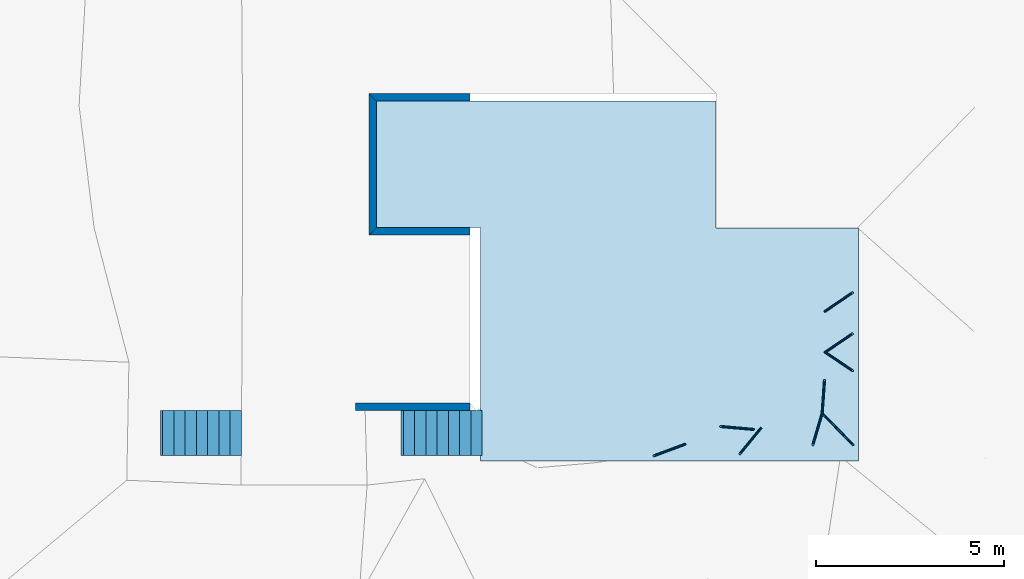
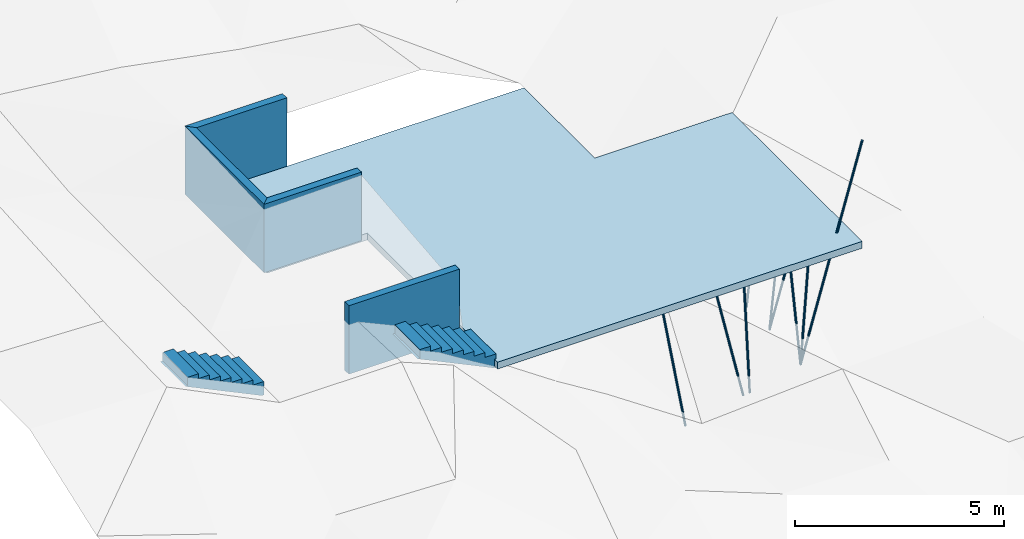
# Not in any storey, part 1 of 2: 9 columns, 4 walls, 2 stair flights, 1 slab.
"""IFC4 model written with IfcOpenShell, lengths in metres."""

from ifc_helpers import new_model, entity, si_unit, converted_unit, frame, origin_with_axes, origin_2d_with_axis, place, context, subcontext, project, line, indexed_curve, circle, outline, extrude, clip, halfspace, polygons, source, transform, mapped, material, layer, layer_set, layer_usage, material_profile, profile_set, profile_usage, type_object, type_shapes, element, save


model = new_model("IFC4")

# Units and contexts
model_context = context("Model", 3, precision=1e-05, world=origin_with_axes())
plan_context = context("Plan", 2, precision=1e-05, world=origin_2d_with_axis())
body_context = subcontext(model_context, "Body", "Model", "MODEL_VIEW")
ifc_project = project(units=[si_unit("LENGTHUNIT", "METRE"), converted_unit("PLANEANGLEUNIT", "degree", entity("IfcReal", 0.0174532925199433), si_unit("PLANEANGLEUNIT", "RADIAN"), dimensions=[0, 0, 0, 0, 0, 0, 0]), si_unit("AREAUNIT", "SQUARE_METRE"), si_unit("VOLUMEUNIT", "CUBIC_METRE")], contexts=[model_context, plan_context])

# Columns
ifc_material = material()
ifc_material_profile = material_profile(ifc_material, circle(Radius=0.0299999993294477))
ifc_profile_set = profile_set([ifc_material_profile])
ifc_profile_usage_1 = profile_usage(ifc_profile_set, cardinal=5)
column_type = type_object("IfcColumnType", Name="Column", PredefinedType="COLUMN", material=ifc_profile_set)
column_1_placement = place(None, frame((4.1066460609436, -0.0712302401661873, -4.02319383621216), z_axis=(0.152964162685084, -0.156363311331579, 0.975783008564648), x_axis=(0.714833945267838, 0.69929423756586, -1.07349813621721e-08)))
element("IfcColumn", 1, at=column_1_placement, type_object=column_type, material=ifc_profile_usage_1, Name="Column", context=body_context, shape_type="SweptSolid", body=[
    extrude(circle(Radius=0.0299999993294477), origin_with_axes(), (0.0, 0.0, 1.0), 7.0000000510897),
])
ifc_profile_usage_2 = profile_usage(ifc_profile_set, cardinal=5)
column_2_placement = place(None, frame((4.1066460609436, -0.0712302401661873, -4.02319383621216), z_axis=(-0.0616105100448784, -0.209884871619059, 0.975783011595027), x_axis=(0.959514275210557, -0.281660000119222, -1.07349815166378e-08)))
element("IfcColumn", 2, at=column_2_placement, type_object=column_type, material=ifc_profile_usage_2, Name="Column", context=body_context, shape_type="SweptSolid", body=[
    extrude(circle(Radius=0.0299999993294477), origin_with_axes(), (0.0, 0.0, 1.0), 3.99999987334013),
])
ifc_profile_usage_3 = profile_usage(ifc_profile_set, cardinal=5)
column_3_placement = place(None, frame((4.1066460609436, -0.0712302401661873, -4.02319383621216), z_axis=(0.0154974454944706, 0.218191062591137, 0.975783013476099), x_axis=(-0.997487086280156, 0.0708485194222474, -1.07349814937929e-08)))
element("IfcColumn", 3, at=column_3_placement, type_object=column_type, material=ifc_profile_usage_3, Name="Column", context=body_context, shape_type="SweptSolid", body=[
    extrude(circle(Radius=0.0299999993294477), origin_with_axes(), (0.0, 0.0, 1.0), 3.99999987334013),
])
ifc_profile_usage_4 = profile_usage(ifc_profile_set, cardinal=5)
column_4_placement = place(None, frame((2.47132182121277, -0.47253680229187, -4.02319383621216), z_axis=(-0.138579714688634, -0.169242937508952, 0.975783014189199), x_axis=(0.77371471493996, -0.63353416631258, -1.07349806949325e-08)))
element("IfcColumn", 4, at=column_4_placement, type_object=column_type, material=ifc_profile_usage_4, Name="Column", context=body_context, shape_type="SweptSolid", body=[
    extrude(circle(Radius=0.0299999993294477), origin_with_axes(), (0.0, 0.0, 1.0), 3.99999987334013),
])
ifc_profile_usage_5 = profile_usage(ifc_profile_set, cardinal=5)
column_5_placement = place(None, frame((4.18690729141235, 1.55406141281128, -4.02319383621216), z_axis=(0.18098047837806, 0.12285590485522, 0.975783015371888), x_axis=(-0.561650777722652, 0.827374403691303, -1.07349816273892e-08)))
element("IfcColumn", 5, at=column_5_placement, type_object=column_type, material=ifc_profile_usage_5, Name="Column", context=body_context, shape_type="SweptSolid", body=[
    extrude(circle(Radius=0.0299999993294477), origin_with_axes(), (0.0, 0.0, 1.0), 3.99999987334013),
])
ifc_profile_usage_6 = profile_usage(ifc_profile_set, cardinal=5)
column_6_placement = place(None, frame((4.18690729141235, 1.55406141281128, -4.02319383621216), z_axis=(0.181584452652041, -0.121961425642809, 0.975783017484027), x_axis=(0.557561659392835, 0.830135528678967, -1.07349816145693e-08)))
element("IfcColumn", 6, at=column_6_placement, type_object=column_type, material=ifc_profile_usage_6, Name="Column", context=body_context, shape_type="SweptSolid", body=[
    extrude(circle(Radius=0.0299999993294477), origin_with_axes(), (0.0, 0.0, 1.0), 3.99999987334013),
])
ifc_profile_usage_7 = profile_usage(ifc_profile_set, cardinal=5)
column_7_placement = place(None, frame((2.27528548240662, -0.501705825328827, -4.02319383621216), z_axis=(-0.217891982431581, 0.0192505946267549, 0.975783018195414), x_axis=(-0.0880065055008526, -0.996119899906396, -1.07349802343716e-08)))
element("IfcColumn", 7, at=column_7_placement, type_object=column_type, material=ifc_profile_usage_7, Name="Column", context=body_context, shape_type="SweptSolid", body=[
    extrude(circle(Radius=0.0299999993294477), origin_with_axes(), (0.0, 0.0, 1.0), 3.99999987334013),
])
ifc_profile_usage_8 = profile_usage(ifc_profile_set, cardinal=5)
column_8_placement = place(None, frame((4.18690729141235, 2.64762187004089, -4.02319383621216), z_axis=(0.18098047837806, 0.12285590485522, 0.975783015371888), x_axis=(-0.561650777722652, 0.827374403691303, -1.07349816273892e-08)))
element("IfcColumn", 8, at=column_8_placement, type_object=column_type, material=ifc_profile_usage_8, Name="Column", context=body_context, shape_type="SweptSolid", body=[
    extrude(circle(Radius=0.0299999993294477), origin_with_axes(), (0.0, 0.0, 1.0), 3.99999987334013),
])
ifc_profile_usage_9 = profile_usage(ifc_profile_set, cardinal=5)
column_9_placement = place(None, frame((0.448067605495453, -0.898925006389618, -4.02319383621216), z_axis=(-0.20505814848983, -0.0761489070684512, 0.975783018754786), x_axis=(0.348124034486287, -0.937448482111412, -1.07349811581041e-08)))
element("IfcColumn", 9, at=column_9_placement, type_object=column_type, material=ifc_profile_usage_9, Name="Column", context=body_context, shape_type="SweptSolid", body=[
    extrude(circle(Radius=0.0299999993294477), origin_with_axes(), (0.0, 0.0, 1.0), 3.99999987334013),
])

# Slab
ifc_layer_1 = layer(ifc_material, 0.200000002980232)
ifc_layer_set_1 = layer_set([ifc_layer_1])
ifc_layer_usage_1 = layer_usage(ifc_layer_set_1, "AXIS3", "POSITIVE", 0.0)
slab_type = type_object("IfcSlabType", Name="Concrete Slab", PredefinedType="FLOOR", material=ifc_layer_set_1)
slab_placement = place(None, frame((1.27500009536743, 0.0, -0.200000002980232), z_axis=(0.0, 0.0, 1.0), x_axis=(1.0, 0.0, 0.0)))
element("IfcSlab", 10, at=slab_placement, type_object=slab_type, material=ifc_layer_usage_1, Name="Slab", context=body_context, shape_type="SweptSolid", body=[
    extrude(outline(indexed_curve([(2.62260437011719e-06, 8.25), (-9.04509925842285, 8.25), (-9.04509925842285, 4.87499904632568), (-6.27499961853027, 4.87499904632568), (-6.27499437332153, -1.34256982803345), (3.79840803146362, -1.34256982803345), (3.79840803146362, 4.86853408813477), (1.9073486328125e-06, 4.86853408813477)], segments=[line(5, 6), line(6, 7), line(7, 8), line(8, 1), line(1, 2), line(2, 3), line(3, 4), line(4, 5)], self_intersect=False)), None, (0.0, 0.0, 1.0), 0.200000002980232),
])

# Walls
ifc_layer_2 = layer(ifc_material, 0.200000002980232)
ifc_layer_set_2 = layer_set([ifc_layer_2])
ifc_layer_usage_2 = layer_usage(ifc_layer_set_2, "AXIS2", "POSITIVE", 0.0)
wall_type = type_object("IfcWallType", Name="Retaining Wall", PredefinedType="SOLIDWALL", material=ifc_layer_set_2)
wall_1_placement = place(None, frame((-7.97009992599487, 4.67499923706055, 0.0), z_axis=(0.0, 0.0, 1.0), x_axis=(1.0, 0.0, 0.0)))
element("IfcWall", 11, at=wall_1_placement, type_object=wall_type, material=ifc_layer_usage_2, Name="Wall", context=body_context, shape_type="Clipping", body=[
    clip(extrude(outline(indexed_curve([(0.0, 0.0), (0.0, 0.200000002980232), (2.69510223010764, 0.200000002980232), (2.69510223010764, 0.0), (0.0, 0.0)], self_intersect=False)), origin_with_axes(), (0.0, 0.0, 1.0), 2.0), halfspace(frame((4.76837158203125e-07, 0.0, 0.0), z_axis=(-0.707107603549957, 0.707105934619904, 0.0), x_axis=(0.707105946721014, 0.707107615651096, 0.0)), False)),
])
ifc_layer_usage_3 = layer_usage(ifc_layer_set_2, "AXIS2", "POSITIVE", 0.0)
wall_2_placement = place(None, frame((-7.97010040283203, 8.44999885559082, 0.0), z_axis=(0.0, 0.0, 1.0), x_axis=(3.13916473260163e-07, -0.999999999999951, 0.0)))
element("IfcWall", 12, at=wall_2_placement, type_object=wall_type, material=ifc_layer_usage_3, Name="Wall", context=body_context, shape_type="Clipping", body=[
    clip(clip(extrude(outline(indexed_curve([(0.0, 0.0), (0.0, 0.200000002980232), (3.77499957558345, 0.200000002980232), (3.77499957558345, 0.0), (0.0, 0.0)], self_intersect=False)), origin_with_axes(), (0.0, 0.0, 1.0), 2.0), halfspace(frame((3.59077148459619e-07, -2.08429128178977e-07, 0.0), z_axis=(-0.707106471061707, 0.707106947898865, 0.0), x_axis=(0.707107019605111, 0.707106542767904, 0.0)), False)), halfspace(frame((3.77500009536743, -4.39789346273756e-07, 0.0), z_axis=(0.707106173038483, 0.707107365131378, 0.0), x_axis=(0.707107377232754, -0.707106185139838, 0.0)), False)),
])
ifc_layer_usage_4 = layer_usage(ifc_layer_set_2, "AXIS2", "POSITIVE", 0.0)
wall_3_placement = place(None, frame((-5.27499914169312, 8.44999980926514, 0.0), z_axis=(0.0, 0.0, 1.0), x_axis=(-0.999999999999924, -3.89414367418765e-07, 0.0)))
element("IfcWall", 13, at=wall_3_placement, type_object=wall_type, material=ifc_layer_usage_4, Name="Wall", context=body_context, shape_type="Clipping", body=[
    clip(extrude(outline(indexed_curve([(0.0, 0.0), (0.0, 0.200000002980232), (2.69510125700749, 0.200000002980232), (2.69510125700749, 0.0), (0.0, 0.0)], self_intersect=False)), origin_with_axes(), (0.0, 0.0, 1.0), 2.0), halfspace(frame((2.69510126113892, -2.42648638959508e-07, 0.0), z_axis=(0.70710700750351, 0.707106411457062, 0.0), x_axis=(0.707106483163231, -0.707107079209739, 0.0)), False)),
])
ifc_layer_usage_5 = layer_usage(ifc_layer_set_2, "AXIS2", "POSITIVE", 0.0)
wall_4_placement = place(None, frame((-8.32677841186523, 0.0, 0.0), z_axis=(0.0, 0.0, 1.0), x_axis=(1.0, 0.0, 0.0)))
element("IfcWall", 14, at=wall_4_placement, type_object=wall_type, material=ifc_layer_usage_5, Name="Wall", context=body_context, shape_type="SweptSolid", body=[
    extrude(outline(indexed_curve([(0.0, 0.0), (0.0, 0.200000002980232), (3.05178062491474, 0.200000002980232), (3.05178062491474, 0.0), (0.0, 0.0)], self_intersect=False)), origin_with_axes(), (0.0, 0.0, 1.0), 2.0),
])

# Stair flights
stair_flight_type = type_object("IfcStairFlightType", Name="Concrete Stairs", PredefinedType="STRAIGHT")
shared_shape = source(origin_with_axes(), body_context, "Body", "Tessellation", [
    polygons([(0.0, 0.0, 0.0), (0.0, 0.0, 0.142857149243355), (0.300000011920929, 0.0, 0.142857149243355), (0.300000011920929, 0.0, 0.28571429848671), (0.600000023841858, 0.0, 0.28571429848671), (0.600000023841858, 0.0, 0.428571462631226), (0.900000035762787, 0.0, 0.428571462631226), (0.900000035762787, 0.0, 0.571428596973419), (1.20000004768372, 0.0, 0.571428596973419), (1.20000004768372, 0.0, 0.714285731315613), (1.5, 0.0, 0.714285731315613), (1.5, 0.0, 0.857142865657806), (1.79999995231628, 0.0, 0.857142865657806), (1.79999995231628, 0.0, 1.0), (2.09999990463257, 0.0, 1.0), (2.09999990463257, 0.0, 0.75), (2.15648531913757, 0.0, 0.75), (0.0564851760864258, 0.0, -0.25), (0.0, 0.0, -0.25), (0.0, 1.20000004768372, 0.142857149243355), (0.300000011920929, 1.20000004768372, 0.142857149243355), (0.300000011920929, 1.20000004768372, 0.28571429848671), (0.600000023841858, 1.20000004768372, 0.28571429848671), (0.600000023841858, 1.20000004768372, 0.428571462631226), (0.900000035762787, 1.20000004768372, 0.428571462631226), (0.900000035762787, 1.20000004768372, 0.571428596973419), (1.20000004768372, 1.20000004768372, 0.571428596973419), (1.20000004768372, 1.20000004768372, 0.714285731315613), (1.5, 1.20000004768372, 0.714285731315613), (1.5, 1.20000004768372, 0.857142865657806), (1.79999995231628, 1.20000004768372, 0.857142865657806), (1.79999995231628, 1.20000004768372, 1.0), (2.09999990463257, 1.20000004768372, 1.0), (2.09999990463257, 1.20000004768372, 0.75), (2.15648531913757, 1.20000004768372, 0.75), (0.0564851760864258, 1.20000004768372, -0.25), (0.0, 1.20000004768372, -0.25), (0.0, 1.20000004768372, 0.0)], [[[2, 1, 19, 18, 17, 16, 15, 14, 13, 12, 11, 10, 9, 8, 7, 6, 5, 4, 3]], [[20, 21, 22, 23, 24, 25, 26, 27, 28, 29, 30, 31, 32, 33, 34, 35, 36, 37, 38]], [[5, 6, 24, 23]], [[13, 14, 32, 31]], [[6, 7, 25, 24]], [[14, 15, 33, 32]], [[7, 8, 26, 25]], [[15, 16, 34, 33]], [[8, 9, 27, 26]], [[1, 2, 20, 38]], [[16, 17, 35, 34]], [[9, 10, 28, 27]], [[2, 3, 21, 20]], [[19, 1, 38, 37]], [[10, 11, 29, 28]], [[3, 4, 22, 21]], [[18, 19, 37, 36]], [[11, 12, 30, 29]], [[4, 5, 23, 22]], [[17, 18, 36, 35]], [[12, 13, 31, 30]]], closed=True),
])
type_shapes(stair_flight_type, [shared_shape])
for number, where, z_axis, x_axis, name in (
    (15, (-4.95622205734253, 0.0, 0.0), (0.0, 0.0, 1.0), (-0.999999999999947, -3.25841369885876e-07, 0.0), "StairFlight"),
    (16, (-11.3669300079346, 0.0, 1.43871033191681), (0.0, 0.0, 1.0), (-0.999999999999947, -3.25841369885876e-07, 0.0), "StairFlight"),
):
    element("IfcStairFlight", number, at=place(None, frame(where, z_axis=z_axis, x_axis=x_axis)), type_object=stair_flight_type, Name=name, context=body_context, shape_type="MappedRepresentation", body=[
        mapped(shared_shape, transform((0.0, 0.0, 0.0), x_axis=(1.0, 0.0, 0.0), y_axis=(0.0, 1.0, 0.0), z_axis=(0.0, 0.0, 1.0), scale=1.0)),
    ])

save(model, "model.ifc")
